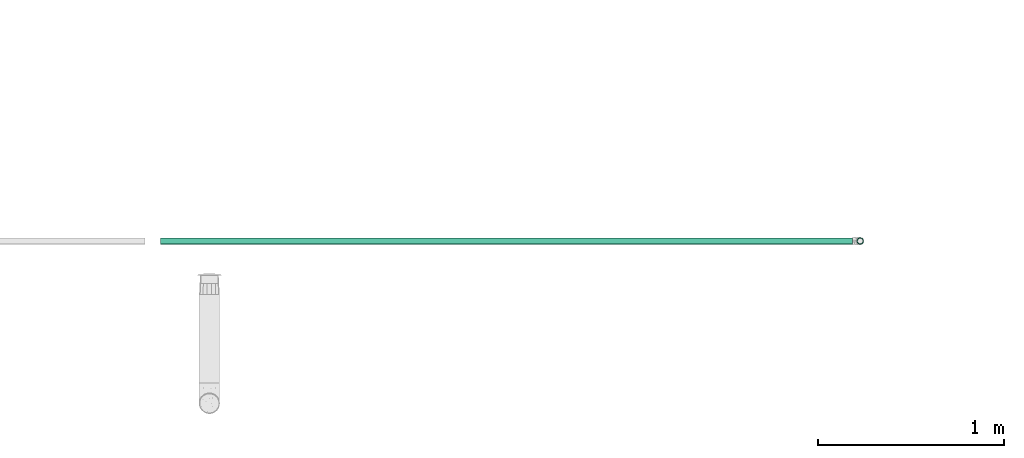
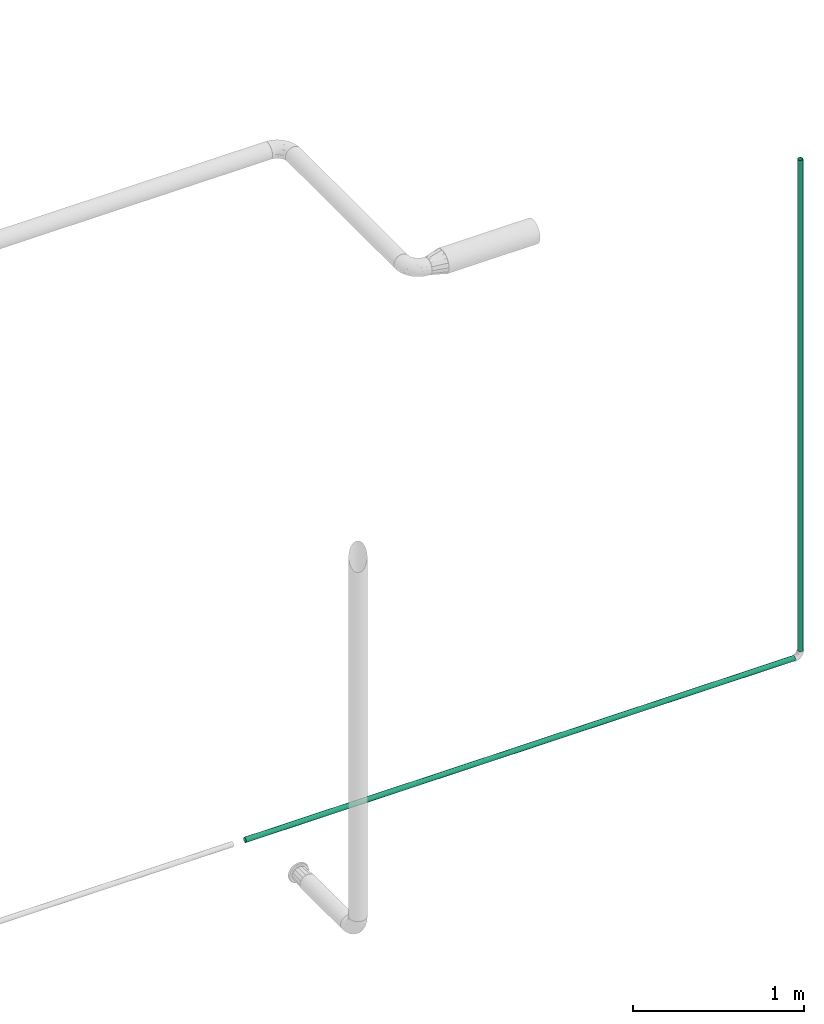
# One storey, part 19 of 123: 2 flow segments.
"""IFC2X3 building model written with IfcOpenShell, lengths in millimetres."""

from ifc_helpers import new_model, entity, si_unit, converted_unit, derived_unit, direction, frame, origin_with_axes, origin_2d_with_axis, place, context, subcontext, project, spatial, hollow_circle, extrude, source, transform, mapped, material, layer, layer_set, layer_usage, type_object, element, save


model = new_model("IFC2X3")

# Units and contexts
model_context = context("Model", 3, precision=1e-05, world=origin_with_axes(), true_north=direction((0.0, 1.0)))
body_context = subcontext(model_context, "Body", "Model", "MODEL_VIEW")
ifc_project = project(units=[si_unit("AREAUNIT", "SQUARE_METRE"), si_unit("VOLUMEUNIT", "CUBIC_METRE", prefix="DECI"), si_unit("TIMEUNIT", "SECOND"), si_unit("THERMODYNAMICTEMPERATUREUNIT", "DEGREE_CELSIUS"), si_unit("PRESSUREUNIT", "PASCAL"), si_unit("MASSUNIT", "GRAM", prefix="KILO"), si_unit("LENGTHUNIT", "METRE", prefix="MILLI"), si_unit("POWERUNIT", "WATT"), si_unit("ELECTRICCURRENTUNIT", "AMPERE"), si_unit("ELECTRICVOLTAGEUNIT", "VOLT"), derived_unit("VOLUMETRICFLOWRATEUNIT", [(si_unit("VOLUMEUNIT", "CUBIC_METRE", prefix="DECI"), 1), (si_unit("TIMEUNIT", "SECOND"), -1)]), derived_unit("LINEARVELOCITYUNIT", [(si_unit("LENGTHUNIT", "METRE"), 1), (si_unit("TIMEUNIT", "SECOND"), -1)]), derived_unit("MASSDENSITYUNIT", [(si_unit("MASSUNIT", "GRAM", prefix="KILO"), 1), (si_unit("VOLUMEUNIT", "CUBIC_METRE"), -1)]), converted_unit("PLANEANGLEUNIT", "DEGREE", entity("IfcRatioMeasure", 0.01745), si_unit("PLANEANGLEUNIT", "RADIAN"), dimensions=[0, 0, 0, 0, 0, 0, 0])], contexts=[model_context])

# Site, building, storey
site_placement = place(None, origin_with_axes())
site = spatial("IfcSite", under=ifc_project, at=site_placement, CompositionType="ELEMENT")
building_placement = place(site_placement, origin_with_axes())
building = spatial("IfcBuilding", under=site, at=building_placement, Name="mc-building", CompositionType="ELEMENT")
storey_placement = place(building_placement, origin_with_axes())
storey = spatial("IfcBuildingStorey", under=building, at=storey_placement, Name="1. Korrus", CompositionType="ELEMENT", Elevation=0.0)

# Flow segments
ifc_material = material(Name="Steel")
ifc_layer = layer(ifc_material, 0.0)
ifc_layer_set = layer_set([ifc_layer], Name="Steel")
ifc_layer_usage = layer_usage(ifc_layer_set, "AXIS1", "POSITIVE", 0.0)
pipe_segment_type = type_object("IfcPipeSegmentType", PredefinedType="RIGIDSEGMENT")
shared_shape_1 = source(origin_with_axes(), body_context, "Body", "SweptSolid", [
    extrude(hollow_circle(Radius=17.5, WallThickness=2.0, at=origin_2d_with_axis()), frame((0.0, 0.0, 0.0), z_axis=(1.0, 0.0, 0.0), x_axis=(0.0, 1.0, 0.0)), (0.0, 0.0, 1.0), 3517.5),
])
flow_segment_1_placement = place(storey_placement, frame((36867.83736, 185.02869, 2561.18858), z_axis=(1.0, 0.0, 0.0), x_axis=(0.0, 0.0, 1.0)))
element("IfcFlowSegment", 1, at=flow_segment_1_placement, inside=storey, type_object=pipe_segment_type, material=ifc_layer_usage, context=body_context, shape_type="MappedRepresentation", body=[
    mapped(shared_shape_1, transform((0.0, 0.0, 0.0), scale=1.0)),
])
shared_shape_2 = source(origin_with_axes(), body_context, "Body", "SweptSolid", [
    extrude(hollow_circle(Radius=17.5, WallThickness=2.0, at=origin_2d_with_axis()), frame((0.0, 0.0, 0.0), z_axis=(1.0, 0.0, 0.0), x_axis=(0.0, 1.0, 0.0)), (0.0, 0.0, 1.0), 3719.3),
])
flow_segment_2_placement = place(storey_placement, frame((33106.09158, 185.02869, 2518.78858), z_axis=(0.0, 0.0, 1.0), x_axis=(1.0, 0.0, 0.0)))
element("IfcFlowSegment", 2, at=flow_segment_2_placement, inside=storey, type_object=pipe_segment_type, material=ifc_layer_usage, context=body_context, shape_type="MappedRepresentation", body=[
    mapped(shared_shape_2, transform((0.0, 0.0, 0.0), scale=1.0)),
])

save(model, "model.ifc")
